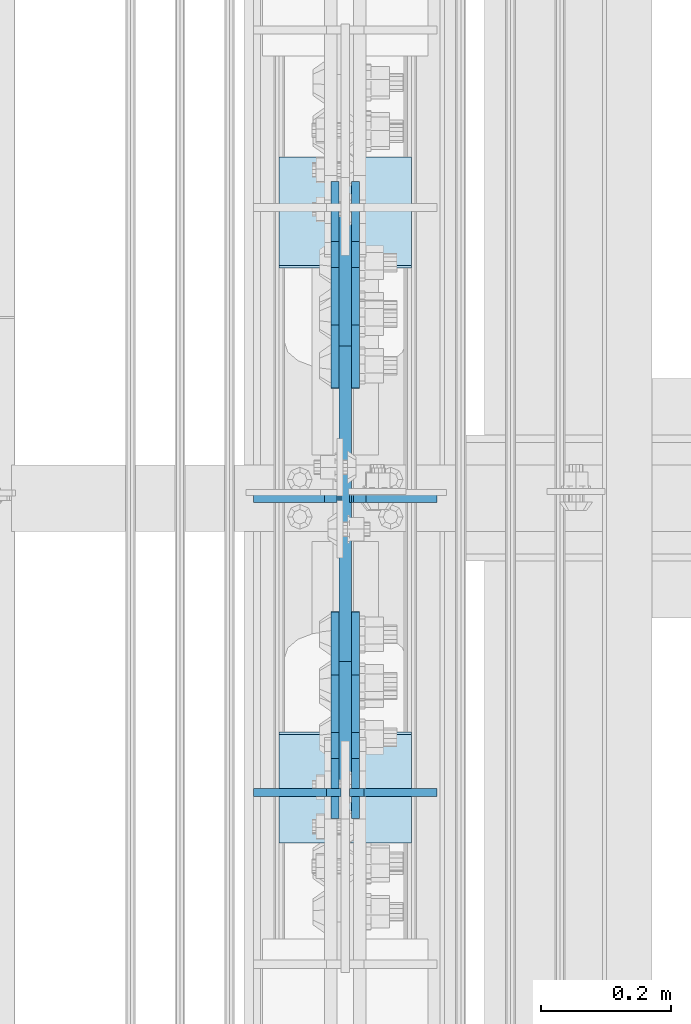
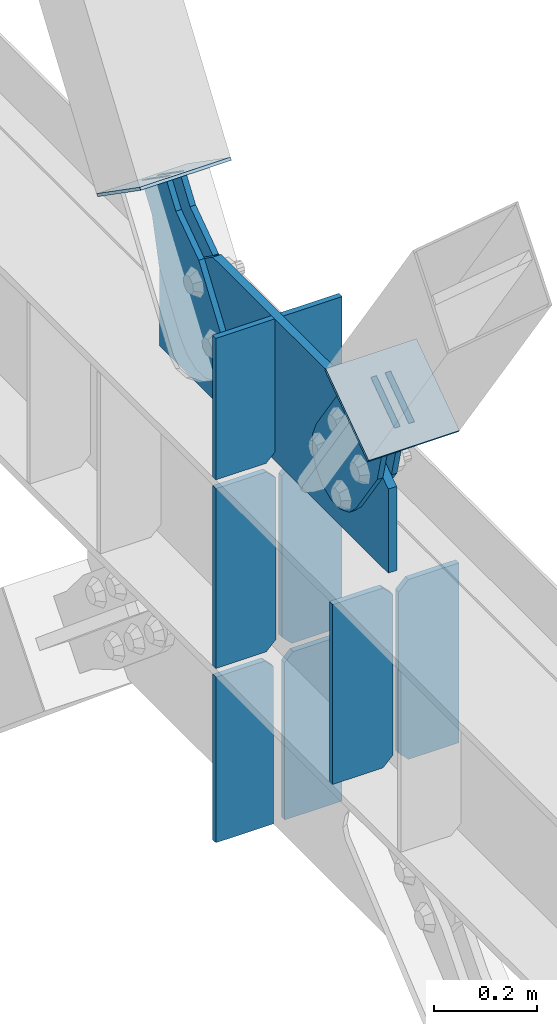
# One storey, part 3178 of 3843: 15 plates, 7 elements without a shape of their own.
"""IFC2X3 building model written with IfcOpenShell, lengths in millimetres."""

import ifcopenshell
import ifcopenshell.guid

model = None  # the IFC model being written
_history = None  # IfcOwnerHistory: only IFC2X3 demands one
_inside = {}  # id of a spatial element -> (the spatial element, [elements in it])
_under = {}  # id of a project, library or spatial element -> (it, [spatial elements below it])
_declared = {}  # id of a project -> (the project, [libraries it declares])
_typed = {}  # id of a type object -> (the type object, [elements of that type])
_made_of = {}  # id of a material, layer set ... -> (it, [elements and type objects made of it])


def new_model(schema):
    """Start an empty IFC model of exactly this schema.

    Asked for "IFC4X3", IfcOpenShell would pick the latest addendum, in which some entities
    have other attributes; the version numbers below select the first issue.
    IFC2X3 requires an IfcOwnerHistory on every rooted entity: one is made here for all.
    """
    global model, _history
    if schema == "IFC4X3":
        model = ifcopenshell.file(schema_version=(4, 3, 0, 0))
    else:
        model = ifcopenshell.file(schema=schema)
    _inside.clear()
    _under.clear()
    _declared.clear()
    _typed.clear()
    _made_of.clear()
    _history = None
    if model.schema == "IFC2X3":
        org = make("IfcOrganization", Name="unknown")
        user = make(
            "IfcPersonAndOrganization",
            ThePerson=make("IfcPerson", FamilyName="unknown"),
            TheOrganization=org,
        )
        app = make(
            "IfcApplication",
            ApplicationDeveloper=org,
            Version="unknown",
            ApplicationFullName="unknown",
            ApplicationIdentifier="unknown",
        )
        _history = make(
            "IfcOwnerHistory",
            OwningUser=user,
            OwningApplication=app,
            ChangeAction="ADDED",
            CreationDate=0,
        )
    return model


def make(cls, **values):
    """One entity of the class cls with the attributes given. An attribute that is None is left unset."""
    return model.create_entity(
        cls, **{name: value for name, value in values.items() if value is not None}
    )


def rooted(cls, **values):
    """An entity with a GlobalId (a new one), such as an element, a storey or a relation."""
    return make(cls, GlobalId=ifcopenshell.guid.new(), OwnerHistory=_history, **values)


def si_unit(unit_type, name, prefix=None):
    """IfcSIUnit, for example si_unit("LENGTHUNIT", "METRE", prefix="MILLI")."""
    return make("IfcSIUnit", UnitType=unit_type, Prefix=prefix, Name=name)


def assignment(units):
    """IfcUnitAssignment: the units of a project."""
    return None if units is None else make("IfcUnitAssignment", Units=units)


def point(xyz):
    """IfcCartesianPoint."""
    return None if xyz is None else make("IfcCartesianPoint", Coordinates=xyz)


def direction(xyz):
    """IfcDirection."""
    return None if xyz is None else make("IfcDirection", DirectionRatios=xyz)


def frame(location, z_axis=None, x_axis=None):
    """IfcAxis2Placement3D, a coordinate frame: its origin and axes. An axis left out is left unset."""
    return make(
        "IfcAxis2Placement3D",
        Location=point(location),
        Axis=direction(z_axis),
        RefDirection=direction(x_axis),
    )


def origin_with_axes():
    """The frame at (0, 0, 0) with the z axis (0, 0, 1) and the x axis (1, 0, 0) written out."""
    return frame((0.0, 0.0, 0.0), z_axis=(0.0, 0.0, 1.0), x_axis=(1.0, 0.0, 0.0))


def place(relative_to, where):
    """IfcLocalPlacement: puts the frame where relative to a parent placement (None: the world)."""
    return make(
        "IfcLocalPlacement", PlacementRelTo=relative_to, RelativePlacement=where
    )


def context(
    kind, dimensions, precision=None, world=None, true_north=None, identifier=None
):
    """IfcGeometricRepresentationContext, for example the 3D "Model" context."""
    return make(
        "IfcGeometricRepresentationContext",
        ContextIdentifier=identifier,
        ContextType=kind,
        CoordinateSpaceDimension=dimensions,
        Precision=precision,
        WorldCoordinateSystem=world,
        TrueNorth=true_north,
    )


def subcontext(parent, identifier, kind, view, scale=None):
    """IfcGeometricRepresentationSubContext, for example "Body" below "Model"."""
    return make(
        "IfcGeometricRepresentationSubContext",
        ContextIdentifier=identifier,
        ContextType=kind,
        ParentContext=parent,
        TargetScale=scale,
        TargetView=view,
    )


def project(units=None, contexts=None):
    """IfcProject with its units and contexts."""
    return rooted(
        "IfcProject",
        Name="project",
        RepresentationContexts=contexts,
        UnitsInContext=assignment(units),
    )


def spatial(cls, under=None, at=None, **own):
    """A site, building, storey or space (cls), placed at a placement, below another one or the project."""
    s = rooted(cls, ObjectPlacement=at, **own)
    if under is not None:
        _under.setdefault(under.id(), (under, []))[1].append(s)
    return s


def faces_of(points, faces, orient=None, outer=None):
    """IfcFace entities. A face is a list of loops; a loop is a list of indices into points, from 0.

    orient and outer hold one flag for each loop. By default every Orientation is true, the
    first loop of a face is its IfcFaceOuterBound and the others are IfcFaceBound.
    """
    made = []
    for i, loops in enumerate(faces):
        bounds = []
        for j, loop in enumerate(loops):
            is_outer = j == 0 if outer is None else outer[i][j]
            bounds.append(
                make(
                    "IfcFaceOuterBound" if is_outer else "IfcFaceBound",
                    Bound=make("IfcPolyLoop", Polygon=[points[k] for k in loop]),
                    Orientation=True if orient is None else orient[i][j],
                )
            )
        made.append(make("IfcFace", Bounds=bounds))
    return made


def faceted_brep(points, faces, orient=None, outer=None, voids=None):
    """IfcFacetedBrep: a solid bounded by flat faces; with voids (closed shells), ...WithVoids."""
    shared = [point(p) for p in points]
    hull = make("IfcClosedShell", CfsFaces=faces_of(shared, faces, orient, outer))
    if voids is None:
        return make("IfcFacetedBrep", Outer=hull)
    return make(
        "IfcFacetedBrepWithVoids",
        Outer=hull,
        Voids=[
            make(cls, CfsFaces=faces_of(shared, fs, o, b)) for cls, fs, o, b in voids
        ],
    )


def shape(context_of_items, identifier, shape_type, items):
    """IfcShapeRepresentation: the items that make up one representation, for example the "Body"."""
    return make(
        "IfcShapeRepresentation",
        ContextOfItems=context_of_items,
        RepresentationIdentifier=identifier,
        RepresentationType=shape_type,
        Items=items,
    )


def material(Name=None, Category=None):
    """IfcMaterial."""
    return make("IfcMaterial", Name=Name, Category=Category)


def made_of(thing, what):
    """Note that an element or type object is made of a material, layer set ...; save() writes the relation."""
    if what is not None:
        _made_of.setdefault(what.id(), (what, []))[1].append(thing)
    return thing


def type_object(cls, material=None, **own):
    """A type object (cls), such as IfcWallType, which elements share."""
    return made_of(rooted(cls, **own), material)


def element(
    cls,
    number,
    at=None,
    inside=None,
    cuts=None,
    type_object=None,
    material=None,
    context=None,
    identifier="Body",
    shape_type=None,
    held_by="IfcProductDefinitionShape",
    body=None,
    shapes=None,
    **own,
):
    """One element of the class cls, such as IfcWall. Its Tag is "e" and its number.

    at: its placement. inside: the storey or other place that contains it. cuts: it is an
    opening in that element (IfcRelVoidsElement). A single representation is given by context,
    identifier, shape_type and body (its items); several are given by shapes. held_by: the class
    of the entity that holds the representations. save() writes the other relations.
    """
    e = rooted(cls, Tag="e%d" % number, ObjectPlacement=at, **own)
    if body is not None:
        shapes = [shape(context, identifier, shape_type, body)]
    if shapes is not None:
        e.Representation = make(held_by, Representations=shapes)
    if inside is not None:
        _inside.setdefault(inside.id(), (inside, []))[1].append(e)
    if cuts is not None:
        rooted(
            "IfcRelVoidsElement", RelatingBuildingElement=cuts, RelatedOpeningElement=e
        )
    if type_object is not None:
        _typed.setdefault(type_object.id(), (type_object, []))[1].append(e)
    return made_of(e, material)


def aggregate(whole, parts):
    """IfcRelAggregates: a whole, such as a stair, and the parts it consists of."""
    return rooted("IfcRelAggregates", RelatingObject=whole, RelatedObjects=parts)


def save(model, path):
    """Write the relations noted so far, then the file.

    IfcRelAggregates (storeys below a building ...), IfcRelContainedInSpatialStructure (elements
    in a storey), IfcRelDefinesByType, IfcRelAssociatesMaterial and IfcRelDeclares: one each for
    every whole, place, type object, material and project.
    """
    for whole, parts in _under.values():
        aggregate(whole, parts)
    for where, things in _inside.values():
        rooted(
            "IfcRelContainedInSpatialStructure",
            RelatedElements=things,
            RelatingStructure=where,
        )
    for kind, things in _typed.values():
        rooted("IfcRelDefinesByType", RelatedObjects=things, RelatingType=kind)
    for what, things in _made_of.values():
        rooted("IfcRelAssociatesMaterial", RelatedObjects=things, RelatingMaterial=what)
    for by, libraries in _declared.values():
        rooted("IfcRelDeclares", RelatingContext=by, RelatedDefinitions=libraries)
    model.write(path)


model = new_model("IFC2X3")

# Units and contexts
model_context = context("Model", 3, precision=1e-05, world=origin_with_axes())
body_context = subcontext(model_context, "Body", "Model", "MODEL_VIEW")
ifc_project = project(units=[si_unit("LENGTHUNIT", "METRE", prefix="MILLI"), si_unit("AREAUNIT", "SQUARE_METRE"), si_unit("VOLUMEUNIT", "CUBIC_METRE"), si_unit("MASSUNIT", "GRAM", prefix="KILO"), si_unit("TIMEUNIT", "SECOND"), si_unit("PLANEANGLEUNIT", "RADIAN"), si_unit("SOLIDANGLEUNIT", "STERADIAN"), si_unit("THERMODYNAMICTEMPERATUREUNIT", "DEGREE_CELSIUS"), si_unit("LUMINOUSINTENSITYUNIT", "LUMEN")], contexts=[model_context])

# Site, building, storey
site_placement = place(None, origin_with_axes())
site = spatial("IfcSite", under=ifc_project, at=site_placement, CompositionType="ELEMENT")
building_placement = place(site_placement, origin_with_axes())
building = spatial("IfcBuilding", under=site, at=building_placement, Name="Undefined", CompositionType="ELEMENT")
storey_placement = place(building_placement, origin_with_axes())
storey = spatial("IfcBuildingStorey", under=building, at=storey_placement, Name="Undefined", CompositionType="ELEMENT", Elevation=0.0)

# Assembly, plates
assembly_1_placement = place(storey_placement, origin_with_axes())
assembly_1 = element("IfcElementAssembly", 1, at=assembly_1_placement, inside=storey, Name="BEAM", AssemblyPlace="NOTDEFINED", PredefinedType="RIGID_FRAME")
ifc_material_1 = material(Name="STEEL/A572-50")
plate_type_1 = type_object("IfcPlateType", PredefinedType="NOTDEFINED")
plate_1_placement = place(assembly_1_placement, frame((77006.45, 19854.8624992641, 34364.6125), z_axis=(-1.0, 0.0, 0.0), x_axis=(0.0, 0.0, 1.0)))
plate_1 = element("IfcPlate", 2, at=plate_1_placement, type_object=plate_type_1, material=ifc_material_1, Name="CB_BEAM", context=body_context, shape_type="Brep", body=[
    faceted_brep([(0.0, -6.34999999999854, 22.2250003814697), (0.0, -6.34999999999854, 134.9375), (0.0, 6.34999999999854, 134.9375), (-2.3032567586398e-12, 6.35, 22.2250003814697), (425.449999999997, -6.34999999999854, 134.9375), (425.449999999997, 6.34999999999854, 134.9375), (425.449999999997, -6.34999999999854, 22.2250003814697), (425.449999999997, 6.34999999999854, 22.2250003814697), (403.224999618527, -6.34999999999854, 0.0), (403.224999618527, 6.34999999999854, 0.0), (22.2250003814697, -6.34999999999854, 0.0), (22.2250003814697, 6.35, 0.0)], [[[0, 1, 2, 3]], [[1, 4, 5, 2]], [[4, 6, 7, 5]], [[6, 8, 9, 7]], [[8, 10, 11, 9]], [[10, 0, 3, 11]], [[5, 7, 9, 11, 3, 2]], [[10, 8, 6, 4, 1, 0]]]),
])
plate_2_placement = place(assembly_1_placement, frame((77019.15, 19854.8624992641, 34364.6125), z_axis=(1.0, 0.0, 0.0), x_axis=(0.0, 0.0, 1.0)))
plate_2 = element("IfcPlate", 3, at=plate_2_placement, type_object=plate_type_1, material=ifc_material_1, Name="CB_BEAM", context=body_context, shape_type="Brep", body=[
    faceted_brep([(0.0, -6.34999999999854, 22.2250003814697), (0.0, -6.34999999999854, 134.9375), (0.0, 6.34999999999854, 134.9375), (-2.3032567586398e-12, 6.35, 22.2250003814697), (425.449999999997, -6.34999999999854, 134.9375), (425.449999999997, 6.34999999999854, 134.9375), (425.449999999997, -6.34999999999854, 22.2250003814697), (425.449999999997, 6.34999999999854, 22.2250003814697), (403.224999618527, -6.34999999999854, 0.0), (403.224999618527, 6.34999999999854, 0.0), (22.2250003814697, -6.34999999999854, 0.0), (22.2250003814697, 6.35, 0.0)], [[[0, 1, 2, 3]], [[1, 4, 5, 2]], [[4, 6, 7, 5]], [[6, 8, 9, 7]], [[8, 10, 11, 9]], [[10, 0, 3, 11]], [[5, 7, 9, 11, 3, 2]], [[10, 8, 6, 4, 1, 0]]]),
])
plate_3_placement = place(assembly_1_placement, frame((77006.45, 20307.2999992641, 34364.6125), z_axis=(-1.0, 0.0, 0.0), x_axis=(0.0, 0.0, 1.0)))
plate_3 = element("IfcPlate", 4, at=plate_3_placement, type_object=plate_type_1, material=ifc_material_1, Name="CB_BEAM", context=body_context, shape_type="Brep", body=[
    faceted_brep([(0.0, -6.34999999999854, 22.2250003814697), (0.0, -6.34999999999854, 134.9375), (0.0, 6.34999999999854, 134.9375), (-2.3032567586398e-12, 6.35, 22.2250003814697), (425.449999999997, -6.34999999999854, 134.9375), (425.449999999997, 6.34999999999854, 134.9375), (425.449999999997, -6.34999999999854, 22.2250003814697), (425.449999999997, 6.34999999999854, 22.2250003814697), (403.224999618527, -6.34999999999854, 0.0), (403.224999618527, 6.34999999999854, 0.0), (22.2250003814697, -6.34999999999854, 0.0), (22.2250003814697, 6.35, 0.0)], [[[0, 1, 2, 3]], [[1, 4, 5, 2]], [[4, 6, 7, 5]], [[6, 8, 9, 7]], [[8, 10, 11, 9]], [[10, 0, 3, 11]], [[5, 7, 9, 11, 3, 2]], [[10, 8, 6, 4, 1, 0]]]),
])
plate_4_placement = place(assembly_1_placement, frame((77019.15, 20307.2999992641, 34364.6125), z_axis=(1.0, 0.0, 0.0), x_axis=(0.0, 0.0, 1.0)))
plate_4 = element("IfcPlate", 5, at=plate_4_placement, type_object=plate_type_1, material=ifc_material_1, Name="CB_BEAM", context=body_context, shape_type="Brep", body=[
    faceted_brep([(0.0, -6.34999999999854, 22.2250003814697), (0.0, -6.34999999999854, 134.9375), (0.0, 6.34999999999854, 134.9375), (-2.3032567586398e-12, 6.35, 22.2250003814697), (425.449999999997, -6.34999999999854, 134.9375), (425.449999999997, 6.34999999999854, 134.9375), (425.449999999997, -6.34999999999854, 22.2250003814697), (425.449999999997, 6.34999999999854, 22.2250003814697), (403.224999618527, -6.34999999999854, 0.0), (403.224999618527, 6.34999999999854, 0.0), (22.2250003814697, -6.34999999999854, 0.0), (22.2250003814697, 6.35, 0.0)], [[[0, 1, 2, 3]], [[1, 4, 5, 2]], [[4, 6, 7, 5]], [[6, 8, 9, 7]], [[8, 10, 11, 9]], [[10, 0, 3, 11]], [[5, 7, 9, 11, 3, 2]], [[10, 8, 6, 4, 1, 0]]]),
])

# Assembly, plate
assembly_2_placement = place(storey_placement, origin_with_axes())
assembly_2 = element("IfcElementAssembly", 6, at=assembly_2_placement, inside=storey, Name="Plate", AssemblyPlace="NOTDEFINED", PredefinedType="RIGID_FRAME")
ifc_material_2 = material(Name="STEEL/A36")
plate_type_2 = type_object("IfcPlateType", PredefinedType="NOTDEFINED")
plate_5_placement = place(assembly_2_placement, frame((77114.4, 20829.8726029218, 35149.7029050663), z_axis=(0.0, -0.820514786824001, 0.571625300877388), x_axis=(-1.0, 0.0, 0.0)))
plate_5 = element("IfcPlate", 7, at=plate_5_placement, type_object=plate_type_2, material=ifc_material_2, Name="Plate", context=body_context, shape_type="Brep", body=[
    faceted_brep([(0.0, -3.17499999999927, 0.0), (0.0, -3.17500000043947, 203.200000001736), (0.0, 3.1749999995518, 203.200000001743), (0.0, 3.17499999999927, 0.0), (203.200000000012, -3.17500000043947, 203.200000001736), (203.200000000012, 3.1749999995518, 203.200000001743), (203.199996948242, -3.17499999999927, 0.0), (203.199996948242, 3.17499999999927, 0.0)], [[[0, 1, 2, 3]], [[1, 4, 5, 2]], [[4, 6, 7, 5]], [[6, 0, 3, 7]], [[5, 7, 3, 2]], [[6, 4, 1, 0]]]),
])
aggregate(assembly_2, [plate_5])

assembly_3_placement = place(storey_placement, origin_with_axes())
assembly_3 = element("IfcElementAssembly", 8, at=assembly_3_placement, inside=storey, Name="Plate", AssemblyPlace="NOTDEFINED", PredefinedType="RIGID_FRAME")
plate_6_placement = place(assembly_3_placement, frame((76911.2, 19779.2826657049, 35157.5183097354), z_axis=(0.0, 0.820514786824002, 0.571625300877387), x_axis=(1.0, 0.0, 0.0)))
plate_6 = element("IfcPlate", 9, at=plate_6_placement, type_object=plate_type_2, material=ifc_material_2, Name="Plate", context=body_context, shape_type="Brep", body=[
    faceted_brep([(0.0, -3.17499999999927, 0.0), (0.0, -3.17500000043947, 203.200000001736), (0.0, 3.1749999995518, 203.200000001743), (0.0, 3.17499999999927, 0.0), (203.200000000012, -3.17500000043947, 203.200000001736), (203.200000000012, 3.1749999995518, 203.200000001743), (203.199996948242, -3.17499999999927, 0.0), (203.199996948242, 3.17499999999927, 0.0)], [[[0, 1, 2, 3]], [[1, 4, 5, 2]], [[4, 6, 7, 5]], [[6, 0, 3, 7]], [[5, 7, 3, 2]], [[6, 4, 1, 0]]]),
])
aggregate(assembly_3, [plate_6])

# Plate
plate_type_3 = type_object("IfcPlateType", PredefinedType="NOTDEFINED")
plate_7_placement = place(assembly_1_placement, frame((77012.8, 19861.144674043, 34810.7), z_axis=(0.0, 1.0, 0.0), x_axis=(0.0, 0.0, 1.0)))
plate_7 = element("IfcPlate", 10, at=plate_7_placement, type_object=plate_type_3, material=ifc_material_1, Name="CB", context=body_context, shape_type="Brep", body=[
    faceted_brep([(0.0, -9.52500000000146, 0.0), (0.0, -9.52499999999418, 886.865920577657), (0.0, 9.52499999999418, 886.865920577657), (0.0, 9.52500000000146, 0.0), (190.948772694501, -9.52499999999418, 886.865920577657), (190.948772694501, 9.52499999999418, 886.865920577657), (334.882452160906, -9.52499999999418, 680.262552702061), (334.882452160906, 9.52499999999418, 680.262552702061), (334.882452160906, -9.52499999999418, 452.505325221086), (334.882452160906, 9.52499999999418, 452.505325221086), (334.882452160906, -9.52499999999418, 195.385083612466), (334.882452160906, 9.52499999999418, 195.385083612466), (198.764177389479, -9.52499999999418, 0.0), (198.764177389479, 9.52499999999418, 0.0)], [[[0, 1, 2, 3]], [[1, 4, 5, 2]], [[4, 6, 7, 5]], [[6, 8, 9, 7]], [[8, 10, 11, 9]], [[10, 12, 13, 11]], [[12, 0, 3, 13]], [[5, 7, 9, 11, 13, 3, 2]], [[12, 10, 8, 6, 4, 1, 0]]]),
])

# Assembly, plate
assembly_4_placement = place(storey_placement, origin_with_axes())
assembly_4 = element("IfcElementAssembly", 11, at=assembly_4_placement, inside=storey, AssemblyPlace="NOTDEFINED", PredefinedType="RIGID_FRAME")
plate_type_4 = type_object("IfcPlateType", PredefinedType="NOTDEFINED")
plate_8_placement = place(assembly_4_placement, frame((76996.925, 20754.4198806679, 35121.0083400061), z_axis=(0.0, -0.820514786824001, 0.571625300877388), x_axis=(0.0, 0.571625300877386, 0.820514786824002)))
plate_8 = element("IfcPlate", 12, at=plate_8_placement, type_object=plate_type_4, material=ifc_material_2, context=body_context, shape_type="Brep", body=[
    faceted_brep([(0.0, -6.3499999046162, 0.0), (-101.600000000049, -6.35000000000582, -37.5700346004523), (-101.600000000049, 6.35000000000582, -37.5700346004523), (7.27595761418343e-12, 6.3499999046162, 0.0), (-245.369242325265, -6.35000000000582, -37.5700346003141), (-245.369242325265, 6.35000000000582, -37.5700346003141), (-281.212328726207, -6.35000000000582, -30.4404014297979), (-281.212328726207, 6.35000000000582, -30.4404014297979), (-311.59863014071, -6.35000000000582, -10.1369239383566), (-311.59863014071, 6.35000000000582, -10.1369239383566), (-331.902107630653, -6.35000000000582, 20.2493774772229), (-331.902107630653, 6.35000000000582, 20.2493774772229), (-339.031740799503, -6.35000000000582, 56.0924669294036), (-339.031740799503, 6.35000000000582, 56.0924669294036), (-331.902107628353, -6.35000000000582, 91.9355533280759), (-331.902107628353, 6.35000000000582, 91.9355533280759), (-311.598630138033, -6.35000000000582, 122.321854740563), (-311.598630138033, 6.35000000000582, 122.321854740563), (-281.212328724767, -6.35000000000582, 142.625332229603), (-281.212328724767, 6.35000000000582, 142.625332229603), (-245.369240796863, -6.35000000000582, 149.754965399145), (-245.369240796863, 6.35000000000582, 149.754965399145), (-101.599999991755, -6.35000000000582, 149.754965398992), (-101.599999991755, 6.35000000000582, 149.754965398992), (4.9622030928731e-09, -6.35000000000582, 112.184930798256), (4.9622030928731e-09, 6.35000000000582, 112.184930798256), (69.8500000038475, -6.35000000000582, 112.184930798168), (69.8500000038475, 6.35000000000582, 112.184930798168), (69.8499999985434, -6.35000000000582, -8.73114913702011e-11), (69.8499999985434, 6.35000000000582, -8.73114913702011e-11)], [[[0, 1, 2, 3]], [[1, 4, 5, 2]], [[4, 6, 7, 5]], [[6, 8, 9, 7]], [[8, 10, 11, 9]], [[10, 12, 13, 11]], [[12, 14, 15, 13]], [[14, 16, 17, 15]], [[16, 18, 19, 17]], [[18, 20, 21, 19]], [[20, 22, 23, 21]], [[22, 24, 25, 23]], [[24, 26, 27, 25]], [[26, 28, 29, 27]], [[28, 0, 3, 29]], [[5, 7, 9, 11, 13, 15, 17, 19, 21, 23, 25, 27, 29, 3, 2]], [[28, 26, 24, 22, 20, 18, 16, 14, 12, 10, 8, 6, 4, 1, 0]]]),
])
aggregate(assembly_4, [plate_8])

assembly_5_placement = place(storey_placement, origin_with_axes())
assembly_5 = element("IfcElementAssembly", 13, at=assembly_5_placement, inside=storey, AssemblyPlace="NOTDEFINED", PredefinedType="RIGID_FRAME")
plate_9_placement = place(assembly_5_placement, frame((77028.675, 20754.4198806679, 35121.0083400061), z_axis=(0.0, -0.820514786824001, 0.571625300877388), x_axis=(0.0, 0.571625300877386, 0.820514786824002)))
plate_9 = element("IfcPlate", 14, at=plate_9_placement, type_object=plate_type_4, material=ifc_material_2, context=body_context, shape_type="Brep", body=[
    faceted_brep([(0.0, -6.3499999046162, 0.0), (-101.600000000049, -6.35000000000582, -37.5700346004523), (-101.600000000049, 6.35000000000582, -37.5700346004523), (7.27595761418343e-12, 6.3499999046162, 0.0), (-245.369242325265, -6.35000000000582, -37.5700346003141), (-245.369242325265, 6.35000000000582, -37.5700346003141), (-281.212328726207, -6.35000000000582, -30.4404014297979), (-281.212328726207, 6.35000000000582, -30.4404014297979), (-311.59863014071, -6.35000000000582, -10.1369239383566), (-311.59863014071, 6.35000000000582, -10.1369239383566), (-331.902107630653, -6.35000000000582, 20.2493774772229), (-331.902107630653, 6.35000000000582, 20.2493774772229), (-339.031740799503, -6.35000000000582, 56.0924669294036), (-339.031740799503, 6.35000000000582, 56.0924669294036), (-331.902107628353, -6.35000000000582, 91.9355533280759), (-331.902107628353, 6.35000000000582, 91.9355533280759), (-311.598630138033, -6.35000000000582, 122.321854740563), (-311.598630138033, 6.35000000000582, 122.321854740563), (-281.212328724767, -6.35000000000582, 142.625332229603), (-281.212328724767, 6.35000000000582, 142.625332229603), (-245.369240796863, -6.35000000000582, 149.754965399145), (-245.369240796863, 6.35000000000582, 149.754965399145), (-101.599999991755, -6.35000000000582, 149.754965398992), (-101.599999991755, 6.35000000000582, 149.754965398992), (4.9622030928731e-09, -6.35000000000582, 112.184930798256), (4.9622030928731e-09, 6.35000000000582, 112.184930798256), (69.8500000038475, -6.35000000000582, 112.184930798168), (69.8500000038475, 6.35000000000582, 112.184930798168), (69.8499999985434, -6.35000000000582, -8.73114913702011e-11), (69.8499999985434, 6.35000000000582, -8.73114913702011e-11)], [[[0, 1, 2, 3]], [[1, 4, 5, 2]], [[4, 6, 7, 5]], [[6, 8, 9, 7]], [[8, 10, 11, 9]], [[10, 12, 13, 11]], [[12, 14, 15, 13]], [[14, 16, 17, 15]], [[16, 18, 19, 17]], [[18, 20, 21, 19]], [[20, 22, 23, 21]], [[22, 24, 25, 23]], [[24, 26, 27, 25]], [[26, 28, 29, 27]], [[28, 0, 3, 29]], [[5, 7, 9, 11, 13, 15, 17, 19, 21, 23, 25, 27, 29, 3, 2]], [[28, 26, 24, 22, 20, 18, 16, 14, 12, 10, 8, 6, 4, 1, 0]]]),
])
aggregate(assembly_5, [plate_9])

assembly_6_placement = place(storey_placement, origin_with_axes())
assembly_6 = element("IfcElementAssembly", 15, at=assembly_6_placement, inside=storey, AssemblyPlace="NOTDEFINED", PredefinedType="RIGID_FRAME")
plate_10_placement = place(assembly_6_placement, frame((76996.925, 19906.8567553096, 35250.2644473823), z_axis=(0.0, -0.820514786824023, -0.571625300877357), x_axis=(0.0, 0.571625300877389, -0.820514786824)))
plate_10 = element("IfcPlate", 16, at=plate_10_placement, type_object=plate_type_4, material=ifc_material_2, context=body_context, shape_type="Brep", body=[
    faceted_brep([(0.0, -6.3499999046162, 0.0), (4.9622030928731e-09, -6.35000000000582, 112.184930798256), (4.9622030928731e-09, 6.35000000000582, 112.184930798256), (7.27595761418343e-12, 6.3499999046162, 0.0), (69.8500000038475, -6.35000000000582, 112.184930798168), (69.8500000038475, 6.35000000000582, 112.184930798168), (171.450000003882, -6.35000000000582, 149.754965398664), (171.450000003882, 6.35000000000582, 149.754965398664), (315.219242329083, -6.35000000000582, 149.754965398519), (315.219242329083, 6.35000000000582, 149.754965398519), (351.06232873004, -6.35000000000582, 142.625332228003), (351.06232873004, 6.35000000000582, 142.625332228003), (381.448630144558, -6.35000000000582, 122.321854736569), (381.448630144558, 6.35000000000582, 122.321854736569), (401.752107634529, -6.35000000000582, 91.9355533209819), (401.752107634529, 6.35000000000582, 91.9355533209819), (408.881740803365, -6.35000000000582, 56.0924638688084), (408.881740803365, 6.35000000000582, 56.0924638688084), (401.75210763223, -6.35000000000582, 20.2493774701215), (401.75210763223, 6.35000000000582, 20.2493774701215), (381.448630141909, -6.35000000000582, -10.1369239423584), (381.448630141909, 6.35000000000582, -10.1369239423584), (351.062328728673, -6.35000000000582, -30.4404014313986), (351.062328728673, 6.35000000000582, -30.4404014313986), (315.219240800725, -6.35000000000582, -37.5700346009617), (315.219240800725, 6.35000000000582, -37.5700346009617), (171.449999995632, -6.35000000000582, -37.5700346008307), (171.449999995632, 6.35000000000582, -37.5700346008307), (69.8499999985434, -6.35000000000582, -8.73114913702011e-11), (69.8499999985434, 6.35000000000582, -8.73114913702011e-11)], [[[0, 1, 2, 3]], [[1, 4, 5, 2]], [[4, 6, 7, 5]], [[6, 8, 9, 7]], [[8, 10, 11, 9]], [[10, 12, 13, 11]], [[12, 14, 15, 13]], [[14, 16, 17, 15]], [[16, 18, 19, 17]], [[18, 20, 21, 19]], [[20, 22, 23, 21]], [[22, 24, 25, 23]], [[24, 26, 27, 25]], [[26, 28, 29, 27]], [[28, 0, 3, 29]], [[5, 7, 9, 11, 13, 15, 17, 19, 21, 23, 25, 27, 29, 3, 2]], [[28, 26, 24, 22, 20, 18, 16, 14, 12, 10, 8, 6, 4, 1, 0]]]),
])
aggregate(assembly_6, [plate_10])

assembly_7_placement = place(storey_placement, origin_with_axes())
assembly_7 = element("IfcElementAssembly", 17, at=assembly_7_placement, inside=storey, AssemblyPlace="NOTDEFINED", PredefinedType="RIGID_FRAME")
plate_11_placement = place(assembly_7_placement, frame((77028.675, 19906.8567553096, 35250.2644473823), z_axis=(0.0, -0.820514786824023, -0.571625300877357), x_axis=(0.0, 0.571625300877389, -0.820514786824)))
plate_11 = element("IfcPlate", 18, at=plate_11_placement, type_object=plate_type_4, material=ifc_material_2, context=body_context, shape_type="Brep", body=[
    faceted_brep([(0.0, -6.3499999046162, 0.0), (4.9622030928731e-09, -6.35000000000582, 112.184930798256), (4.9622030928731e-09, 6.35000000000582, 112.184930798256), (7.27595761418343e-12, 6.3499999046162, 0.0), (69.8500000038475, -6.35000000000582, 112.184930798168), (69.8500000038475, 6.35000000000582, 112.184930798168), (171.450000003882, -6.35000000000582, 149.754965398664), (171.450000003882, 6.35000000000582, 149.754965398664), (315.219242329083, -6.35000000000582, 149.754965398519), (315.219242329083, 6.35000000000582, 149.754965398519), (351.06232873004, -6.35000000000582, 142.625332228003), (351.06232873004, 6.35000000000582, 142.625332228003), (381.448630144558, -6.35000000000582, 122.321854736569), (381.448630144558, 6.35000000000582, 122.321854736569), (401.752107634529, -6.35000000000582, 91.9355533209819), (401.752107634529, 6.35000000000582, 91.9355533209819), (408.881740803365, -6.35000000000582, 56.0924638688084), (408.881740803365, 6.35000000000582, 56.0924638688084), (401.75210763223, -6.35000000000582, 20.2493774701215), (401.75210763223, 6.35000000000582, 20.2493774701215), (381.448630141909, -6.35000000000582, -10.1369239423584), (381.448630141909, 6.35000000000582, -10.1369239423584), (351.062328728673, -6.35000000000582, -30.4404014313986), (351.062328728673, 6.35000000000582, -30.4404014313986), (315.219240800725, -6.35000000000582, -37.5700346009617), (315.219240800725, 6.35000000000582, -37.5700346009617), (171.449999995632, -6.35000000000582, -37.5700346008307), (171.449999995632, 6.35000000000582, -37.5700346008307), (69.8499999985434, -6.35000000000582, -8.73114913702011e-11), (69.8499999985434, 6.35000000000582, -8.73114913702011e-11)], [[[0, 1, 2, 3]], [[1, 4, 5, 2]], [[4, 6, 7, 5]], [[6, 8, 9, 7]], [[8, 10, 11, 9]], [[10, 12, 13, 11]], [[12, 14, 15, 13]], [[14, 16, 17, 15]], [[16, 18, 19, 17]], [[18, 20, 21, 19]], [[20, 22, 23, 21]], [[22, 24, 25, 23]], [[24, 26, 27, 25]], [[26, 28, 29, 27]], [[28, 0, 3, 29]], [[5, 7, 9, 11, 13, 15, 17, 19, 21, 23, 25, 27, 29, 3, 2]], [[28, 26, 24, 22, 20, 18, 16, 14, 12, 10, 8, 6, 4, 1, 0]]]),
])
aggregate(assembly_7, [plate_11])

# Plate
plate_type_5 = type_object("IfcPlateType", PredefinedType="NOTDEFINED")
plate_12_placement = place(assembly_1_placement, frame((77000.1, 20307.2999992641, 33952.457812), z_axis=(-1.0, 0.0, 0.0), x_axis=(0.0, 0.0, 1.0)))
plate_12 = element("IfcPlate", 19, at=plate_12_placement, type_object=plate_type_5, material=ifc_material_1, Name="CB", context=body_context, shape_type="Brep", body=[
    faceted_brep([(0.0, -6.3499999046162, 0.0), (0.0, -6.34999999999854, 128.587500000009), (0.0, 6.34999999999854, 128.587500000009), (7.27595761418343e-12, 6.3499999046162, 0.0), (391.589767330108, -6.34999999999854, 128.587500000009), (391.589767330108, 6.34999999999854, 128.587500000009), (391.589767330108, -6.34999999999854, 19.0499992370605), (391.589767330108, 6.34999999999854, 19.0499992370605), (372.539768093047, -6.34999999999854, 0.0), (372.539768093047, 6.34999999999854, 0.0)], [[[0, 1, 2, 3]], [[1, 4, 5, 2]], [[4, 6, 7, 5]], [[6, 8, 9, 7]], [[8, 0, 3, 9]], [[5, 7, 9, 3, 2]], [[8, 6, 4, 1, 0]]]),
])

plate_13_placement = place(assembly_1_placement, frame((77025.5, 20307.2999992641, 33952.457812), z_axis=(1.0, 0.0, 0.0), x_axis=(0.0, 0.0, 1.0)))
plate_13 = element("IfcPlate", 20, at=plate_13_placement, type_object=plate_type_5, material=ifc_material_1, Name="CB", context=body_context, shape_type="Brep", body=[
    faceted_brep([(0.0, -6.3499999046162, 0.0), (0.0, -6.34999999999854, 128.587500000009), (0.0, 6.34999999999854, 128.587500000009), (7.27595761418343e-12, 6.3499999046162, 0.0), (391.589767330108, -6.34999999999854, 128.587500000009), (391.589767330108, 6.34999999999854, 128.587500000009), (391.589767330108, -6.34999999999854, 19.0499992370605), (391.589767330108, 6.34999999999854, 19.0499992370605), (372.539768093047, -6.34999999999854, 0.0), (372.539768093047, 6.34999999999854, 0.0)], [[[0, 1, 2, 3]], [[1, 4, 5, 2]], [[4, 6, 7, 5]], [[6, 8, 9, 7]], [[8, 0, 3, 9]], [[5, 7, 9, 3, 2]], [[8, 6, 4, 1, 0]]]),
])

plate_type_6 = type_object("IfcPlateType", PredefinedType="NOTDEFINED")
plate_14_placement = place(assembly_1_placement, frame((77003.275, 20307.3000003904, 34810.7), z_axis=(-1.0, 0.0, 0.0), x_axis=(0.0, 0.0, 1.0)))
plate_14 = element("IfcPlate", 21, at=plate_14_placement, type_object=plate_type_6, material=ifc_material_1, Name="CB", context=body_context, shape_type="Brep", body=[
    faceted_brep([(0.0, -6.34999999999854, 19.0499992370605), (0.0, -6.35000000000582, 131.762499999997), (0.0, 6.35000000000582, 131.762499999997), (0.0, 6.34999999999854, 19.0499992370605), (334.882452160906, -6.34999999999854, 131.762500000012), (334.882452160906, 6.34999999999854, 131.762500000012), (334.882452160906, -6.34999999999854, 0.0), (334.882452160906, 6.34999999999854, 0.0), (19.0499992370605, -6.34999999999854, 0.0), (19.0499992370605, 6.34999999999854, 0.0)], [[[0, 1, 2, 3]], [[1, 4, 5, 2]], [[4, 6, 7, 5]], [[6, 8, 9, 7]], [[8, 0, 3, 9]], [[5, 7, 9, 3, 2]], [[8, 6, 4, 1, 0]]]),
])

plate_15_placement = place(assembly_1_placement, frame((77022.325, 20307.3000003904, 34810.7), z_axis=(1.0, 0.0, 0.0), x_axis=(0.0, 0.0, 1.0)))
plate_15 = element("IfcPlate", 22, at=plate_15_placement, type_object=plate_type_6, material=ifc_material_1, Name="CB", context=body_context, shape_type="Brep", body=[
    faceted_brep([(0.0, -6.34999999999854, 19.0499992370605), (0.0, -6.35000000000582, 131.762499999997), (0.0, 6.35000000000582, 131.762499999997), (0.0, 6.34999999999854, 19.0499992370605), (334.882452160906, -6.34999999999854, 131.762500000012), (334.882452160906, 6.34999999999854, 131.762500000012), (334.882452160906, -6.34999999999854, 0.0), (334.882452160906, 6.34999999999854, 0.0), (19.0499992370605, -6.34999999999854, 0.0), (19.0499992370605, 6.34999999999854, 0.0)], [[[0, 1, 2, 3]], [[1, 4, 5, 2]], [[4, 6, 7, 5]], [[6, 8, 9, 7]], [[8, 0, 3, 9]], [[5, 7, 9, 3, 2]], [[8, 6, 4, 1, 0]]]),
])

aggregate(assembly_1, [plate_1, plate_2, plate_3, plate_4, plate_12, plate_13, plate_14, plate_15, plate_7])

save(model, "model.ifc")
